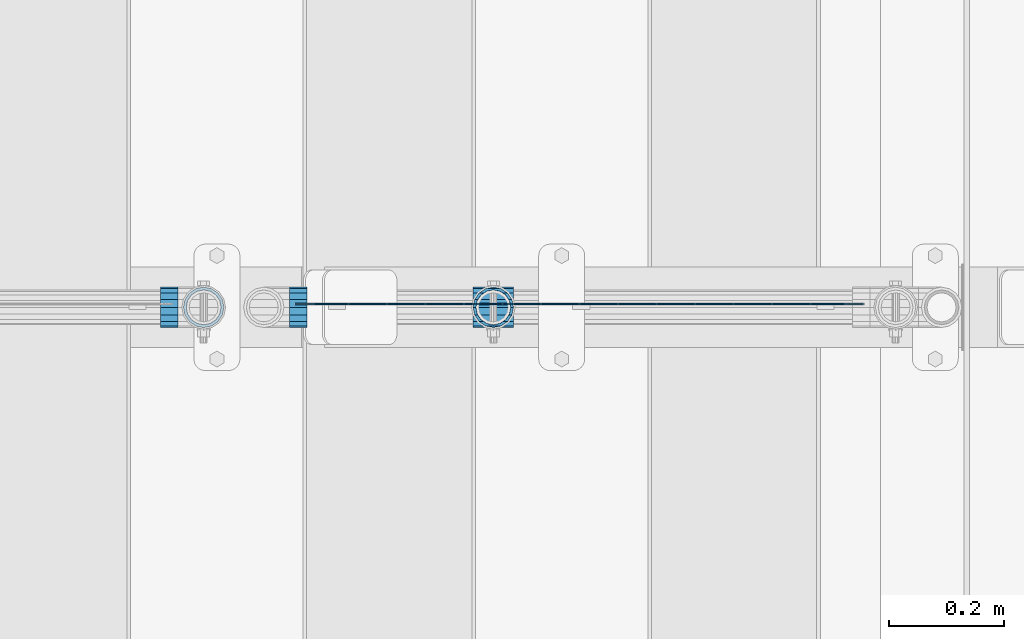
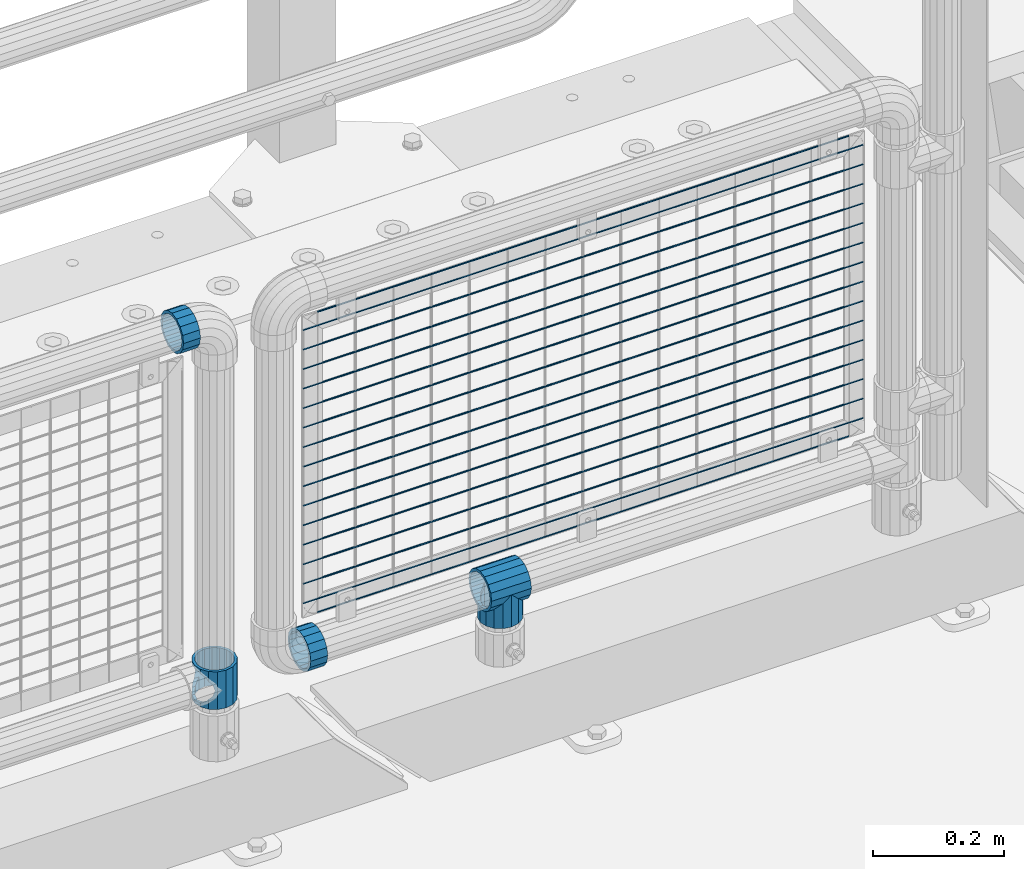
# One storey, part 124 of 193: 22 beams.
"""IFC2X3 building model written with IfcOpenShell, lengths in millimetres."""

from ifc_helpers import new_model, si_unit, frame, origin_with_axes, place, context, subcontext, project, spatial, faceted_brep, material, type_object, element, save


model = new_model("IFC2X3")

# Units and contexts
model_context = context("Model", 3, precision=1e-05, world=origin_with_axes())
body_context = subcontext(model_context, "Body", "Model", "MODEL_VIEW")
ifc_project = project(units=[si_unit("LENGTHUNIT", "METRE", prefix="MILLI"), si_unit("AREAUNIT", "SQUARE_METRE"), si_unit("VOLUMEUNIT", "CUBIC_METRE"), si_unit("MASSUNIT", "GRAM", prefix="KILO"), si_unit("TIMEUNIT", "SECOND"), si_unit("PLANEANGLEUNIT", "RADIAN"), si_unit("SOLIDANGLEUNIT", "STERADIAN"), si_unit("THERMODYNAMICTEMPERATUREUNIT", "DEGREE_CELSIUS"), si_unit("LUMINOUSINTENSITYUNIT", "LUMEN")], contexts=[model_context])

# Site, building, storey
site_placement = place(None, origin_with_axes())
site = spatial("IfcSite", under=ifc_project, at=site_placement, CompositionType="ELEMENT")
building_placement = place(site_placement, origin_with_axes())
building = spatial("IfcBuilding", under=site, at=building_placement, Name="Standard", CompositionType="ELEMENT")
storey_placement = place(building_placement, origin_with_axes())
storey = spatial("IfcBuildingStorey", under=building, at=storey_placement, Name="Undefined", CompositionType="ELEMENT", Elevation=0.0)

# Beams
ifc_material = material(Name="Misc_Undefined")
beam_type_1 = type_object("IfcBeamType", PredefinedType="NOTDEFINED")
beam_1_placement = place(storey_placement, frame((-30223.0, 28664.5, 333.820000000001), z_axis=(1.0, 0.0, 0.0), x_axis=(0.0, 0.0, -1.0)))
element("IfcBeam", 1, at=beam_1_placement, inside=storey, type_object=beam_type_1, material=ifc_material, context=body_context, shape_type="Brep", body=[
    faceted_brep([(46.7644421722801, 28.0397438117179, -11.614442172282), (46.7644421722801, 28.0397438117179, -20.0882031229849), (51.5310424080006, 24.8548033587067, -24.8548033587067), (56.6106908090114, 21.46069080901, -27.1226768591041), (56.6106908090114, 21.46069080901, -21.46069080901), (61.9623795176744, 13.4513226476338, -32.4743655677703), (63.1897438117172, 11.614442172282, -32.8397438117245), (63.1897438117172, 11.614442172282, -28.0397438117179), (65.4999999999997, 0.0, -35.1500000000015), (65.4999999999997, 0.0, -30.3499999999985), (63.1897438117172, -11.614442172282, -32.8397438117172), (63.1897438117172, -11.614442172282, -28.0397438117179), (61.9623795176767, -13.4513226476338, -32.4743655677703), (56.6106908090114, -21.46069080901, -27.1226768591114), (56.6106908090114, -21.46069080901, -21.46069080901), (51.5310424080006, -24.8548033587067, -24.8548033587067), (46.7644421722801, -28.0397438117179, -20.0882031229812), (46.7644421722801, -28.0397438117179, -11.614442172282), (35.1499999999996, -30.3499999999985, -16.6306603983721), (35.1500000000015, -30.35, 0.0), (23.5355578277191, -28.0397438117179, -20.0882031229812), (23.5355578277191, -28.0397438117179, -11.614442172282), (18.7689575919921, -24.8548033587067, -24.8548033587067), (13.6893091909879, -21.46069080901, -27.1226768591114), (13.6893091909879, -21.46069080901, -21.46069080901), (8.33762048232484, -13.4513226476338, -32.4743655677703), (7.11025618828211, -11.614442172282, -32.8397438117172), (7.11025618828211, -11.614442172282, -28.0397438117179), (4.79999999999961, 0.0, -35.1500000000015), (4.79999999999961, 0.0, -30.3499999999985), (7.11025618828211, 11.614442172282, -32.8397438117245), (7.11025618828211, 11.614442172282, -28.0397438117179), (8.33762048232262, 13.4513226476338, -32.4743655677703), (13.6893091909879, 21.46069080901, -27.1226768591041), (13.6893091909879, 21.46069080901, -21.46069080901), (18.7689575919987, 24.8548033587067, -24.8548033587067), (23.5355578277192, 28.0397438117179, -20.0882031229849), (23.5355578277192, 28.0397438117179, -11.614442172282), (35.1499999999996, 30.3499999999985, -16.6306603983685), (35.1500000000015, 30.35, 0.0), (0.0, 32.4743655677703, -13.4513226476338), (0.0, 35.1500000000015, 0.0), (70.2999999999993, 35.1500000000015, 0.0), (70.2999999999993, 32.4743655677703, -13.4513226476338), (0.0, 32.4743655677703, 13.4513226476338), (70.2999999999993, 32.4743655677703, 13.4513226476338), (0.0, 24.8548033587067, 24.8548033587067), (70.2999999999993, 24.8548033587067, 24.8548033587067), (0.0, 13.4513226476338, 32.4743655677703), (70.2999999999993, 13.4513226476338, 32.4743655677703), (0.0, 0.0, 35.1500000000015), (70.2999999999993, 0.0, 35.1500000000015), (0.0, -13.4513226476338, 32.4743655677703), (70.2999999999993, -13.4513226476338, 32.4743655677703), (0.0, -24.8548033587067, 24.8548033587067), (70.2999999999993, -24.8548033587067, 24.8548033587067), (0.0, -32.4743655677703, 13.4513226476338), (70.2999999999993, -32.4743655677703, 13.4513226476338), (0.0, -35.1500000000015, 0.0), (70.2999999999993, -35.1500000000015, 0.0), (70.2999999999993, -30.3499999999985, 0.0), (70.2999999999993, -28.0397438117179, -11.614442172282), (70.2999999999993, -21.46069080901, -21.46069080901), (70.2999999999993, -11.614442172282, -28.0397438117179), (70.2999999999993, 0.0, -30.3499999999985), (70.2999999999993, 11.614442172282, -28.0397438117179), (70.2999999999993, 21.46069080901, -21.46069080901), (70.2999999999993, 28.0397438117179, -11.614442172282), (0.0, -28.0397438117179, -11.614442172282), (0.0, -30.3499999999985, 0.0), (0.0, -21.46069080901, -21.46069080901), (0.0, -11.614442172282, -28.0397438117179), (0.0, 0.0, -30.3499999999985), (0.0, 11.614442172282, -28.0397438117179), (0.0, 21.46069080901, -21.46069080901), (0.0, 28.0397438117179, -11.614442172282), (0.0, 30.3499999999985, 0.0), (70.2999999999993, 30.3499999999985, 0.0), (0.0, 28.0397438117179, 11.614442172282), (70.2999999999993, 28.0397438117179, 11.614442172282), (0.0, 21.46069080901, 21.46069080901), (70.2999999999993, 21.46069080901, 21.46069080901), (0.0, 11.614442172282, 28.0397438117179), (70.2999999999993, 11.614442172282, 28.0397438117179), (0.0, 0.0, 30.3499999999985), (70.2999999999993, 0.0, 30.3499999999985), (0.0, -11.614442172282, 28.0397438117179), (70.2999999999993, -11.614442172282, 28.0397438117179), (0.0, -21.46069080901, 21.46069080901), (70.2999999999993, -21.46069080901, 21.46069080901), (0.0, -28.0397438117179, 11.614442172282), (70.2999999999993, -28.0397438117179, 11.614442172282), (70.2999999999993, -24.8548033587067, -24.8548033587067), (70.2999999999993, -13.4513226476338, -32.4743655677703), (70.2999999999993, 0.0, -35.1500000000015), (70.2999999999993, 13.4513226476338, -32.4743655677703), (70.2999999999993, 24.8548033587067, -24.8548033587067), (70.2999999999993, -32.4743655677703, -13.4513226476338), (0.0, -32.4743655677703, -13.4513226476338), (0.0, 24.8548033587067, -24.8548033587067), (0.0, 13.4513226476338, -32.4743655677703), (0.0, 0.0, -35.1500000000015), (0.0, -13.4513226476338, -32.4743655677703), (0.0, -24.8548033587067, -24.8548033587067)], [[[0, 1, 2, 3, 4]], [[4, 3, 5, 6, 7]], [[7, 6, 8, 9]], [[9, 8, 10, 11]], [[11, 10, 12, 13, 14]], [[14, 13, 15, 16, 17]], [[17, 16, 18, 19]], [[19, 18, 20, 21]], [[21, 20, 22, 23, 24]], [[24, 23, 25, 26, 27]], [[27, 26, 28, 29]], [[29, 28, 30, 31]], [[31, 30, 32, 33, 34]], [[34, 33, 35, 36, 37]], [[37, 36, 38, 39]], [[39, 38, 1, 0]], [[40, 41, 42, 43]], [[41, 44, 45, 42]], [[44, 46, 47, 45]], [[46, 48, 49, 47]], [[48, 50, 51, 49]], [[50, 52, 53, 51]], [[52, 54, 55, 53]], [[54, 56, 57, 55]], [[56, 58, 59, 57]], [[60, 61, 17, 19]], [[61, 62, 14, 17]], [[62, 63, 11, 14]], [[63, 64, 9, 11]], [[64, 65, 7, 9]], [[65, 66, 4, 7]], [[66, 67, 0, 4]], [[68, 69, 19, 21]], [[70, 68, 21, 24]], [[71, 70, 24, 27]], [[72, 71, 27, 29]], [[73, 72, 29, 31]], [[74, 73, 31, 34]], [[75, 74, 34, 37]], [[76, 75, 37, 39]], [[67, 77, 39, 0]], [[78, 76, 39, 77, 79]], [[80, 78, 79, 81]], [[82, 80, 81, 83]], [[84, 82, 83, 85]], [[86, 84, 85, 87]], [[88, 86, 87, 89]], [[90, 88, 89, 91]], [[19, 69, 90, 91, 60]], [[92, 93, 94, 95, 96, 43, 42, 45, 47, 49, 51, 53, 55, 57, 59, 97], [89, 87, 85, 83, 81, 79, 77, 67, 66, 65, 64, 63, 62, 61, 60, 91]], [[58, 98, 97, 59]], [[56, 54, 52, 50, 48, 46, 44, 41, 40, 99, 100, 101, 102, 103, 98, 58], [68, 70, 71, 72, 73, 74, 75, 76, 78, 80, 82, 84, 86, 88, 90, 69]], [[32, 100, 99, 35, 33]], [[28, 101, 100, 32, 30]], [[102, 101, 28, 26, 25]], [[103, 102, 25, 23, 22]], [[15, 92, 97, 98, 103, 22, 20, 18, 16]], [[12, 93, 92, 15, 13]], [[8, 94, 93, 12, 10]], [[95, 94, 8, 6, 5]], [[96, 95, 5, 3, 2]], [[35, 99, 40, 43, 96, 2, 1, 38, 36]]]),
])
beam_2_placement = place(storey_placement, frame((-29719.0, 28664.5, 298.169999999999), z_axis=(0.0, 1.0, 0.0), x_axis=(0.0, 0.0, -1.0)))
element("IfcBeam", 2, at=beam_2_placement, inside=storey, type_object=beam_type_1, material=ifc_material, context=body_context, shape_type="Brep", body=[
    faceted_brep([(0.0, 0.0, 35.1500000000015), (13.4513226476338, 13.4513226476329, 32.4743655677703), (13.4513226476338, -13.4513226476329, 32.4743655677703), (24.8548033587067, -16.3810424080013, -24.8548033587067), (24.8548033587067, -24.8548033587072, -24.8548033587067), (32.4743655677703, -32.4743655677717, -13.4513226476338), (32.4743655677703, -26.8123795176754, -13.4513226476338), (27.1226768591114, -21.4606908090117, -21.46069080901), (0.0, 0.0, -35.1500000000015), (13.4513226476338, -13.4513226476329, -32.4743655677703), (13.4513226476338, 13.4513226476329, -32.4743655677703), (20.0882031229849, -11.6144421722805, -28.0397438117179), (16.6306603983721, 0.0, -30.3499999999985), (20.0882031229849, 11.6144421722805, -28.0397438117179), (24.8548033587067, 16.3810424080013, -24.8548033587067), (24.8548033587067, 24.8548033587072, -24.8548033587067), (27.1226768591114, 21.4606908090117, -21.46069080901), (32.4743655677703, 26.8123795176776, -13.4513226476338), (32.4743655677703, 32.4743655677717, -13.4513226476338), (32.8397438117172, 28.0397438117175, -11.614442172282), (35.1500000000015, 30.35, 0.0), (35.1500000000015, 35.15, 0.0), (32.8397438117208, 28.0397438117175, 11.614442172282), (32.4743655677703, 26.8123795176754, 13.4513226476338), (32.4743655677703, 32.4743655677717, 13.4513226476338), (27.1226768591041, 21.4606908090117, 21.46069080901), (24.8548033587067, 16.3810424080078, 24.8548033587067), (24.8548033587067, 24.8548033587072, 24.8548033587067), (20.0882031229849, 11.6144421722805, 28.0397438117179), (16.6306603983685, 0.0, 30.3499999999985), (20.0882031229849, -11.6144421722805, 28.0397438117179), (24.8548033587067, -16.3810424080013, 24.8548033587067), (24.8548033587067, -24.8548033587072, 24.8548033587067), (27.1226768591041, -21.4606908090117, 21.46069080901), (32.4743655677703, -26.8123795176776, 13.4513226476338), (32.4743655677703, -32.4743655677717, 13.4513226476338), (32.8397438117208, -28.0397438117175, 11.614442172282), (35.1500000000015, -30.35, 0.0), (35.1500000000015, -35.15, 0.0), (32.8397438117172, -28.0397438117175, -11.614442172282), (60.1500000000015, -24.8548033587072, -24.8548033587067), (60.1500000000015, -32.4743655677717, -13.4513226476338), (60.1500000000015, -13.4513226476329, -32.4743655677703), (60.1500000000015, 0.0, -35.1500000000015), (60.1500000000015, 13.4513226476329, -32.4743655677703), (60.1500000000015, 24.8548033587072, -24.8548033587067), (60.1500000000015, 32.4743655677717, -13.4513226476338), (60.1500000000015, 35.15, 0.0), (60.1500000000015, 32.4743655677717, 13.4513226476338), (60.1500000000015, 24.8548033587072, 24.8548033587067), (60.1500000000015, 13.4513226476329, 32.4743655677703), (60.1500000000015, 0.0, 35.1500000000015), (60.1500000000015, -13.4513226476329, 32.4743655677703), (60.1500000000015, -24.8548033587072, 24.8548033587067), (60.1500000000015, -32.4743655677717, 13.4513226476338), (60.1500000000015, -35.15, 0.0), (60.1500000000015, -21.4606908090117, 21.46069080901), (60.1500000000015, -11.6144421722805, 28.0397438117179), (60.1500000000015, 0.0, 30.3499999999985), (60.1500000000015, 11.6144421722805, 28.0397438117179), (60.1500000000015, 21.4606908090117, 21.46069080901), (60.1500000000015, 28.0397438117175, 11.614442172282), (60.1500000000015, 30.35, 0.0), (60.1500000000015, 28.0397438117175, -11.614442172282), (60.1500000000015, 21.4606908090117, -21.46069080901), (60.1500000000015, 11.6144421722805, -28.0397438117179), (60.1500000000015, 0.0, -30.3499999999985), (60.1500000000015, -11.6144421722805, -28.0397438117179), (60.1500000000015, -21.4606908090117, -21.46069080901), (60.1500000000015, -28.0397438117175, -11.614442172282), (60.1500000000015, -30.35, 0.0), (60.1500000000015, -28.0397438117175, 11.614442172282)], [[[0, 1, 2]], [[3, 4, 5, 6, 7]], [[8, 9, 10]], [[10, 9, 4, 3, 11, 12, 13, 14, 15]], [[15, 14, 16, 17, 18]], [[18, 17, 19, 20, 21]], [[21, 20, 22, 23, 24]], [[24, 23, 25, 26, 27]], [[27, 26, 28, 29, 30, 31, 32, 2, 1]], [[33, 34, 35, 32, 31]], [[36, 37, 38, 35, 34]], [[6, 5, 38, 37, 39]], [[40, 41, 5, 4]], [[42, 40, 4, 9]], [[43, 42, 9, 8]], [[44, 43, 8, 10]], [[45, 44, 10, 15]], [[46, 45, 15, 18]], [[47, 46, 18, 21]], [[48, 47, 21, 24]], [[49, 48, 24, 27]], [[50, 49, 27, 1]], [[51, 50, 1, 0]], [[52, 51, 0, 2]], [[53, 52, 2, 32]], [[54, 53, 32, 35]], [[55, 54, 35, 38]], [[41, 55, 38, 5]], [[40, 42, 43, 44, 45, 46, 47, 48, 49, 50, 51, 52, 53, 54, 55, 41], [56, 57, 58, 59, 60, 61, 62, 63, 64, 65, 66, 67, 68, 69, 70, 71]], [[71, 70, 37, 36]], [[56, 71, 36, 34, 33]], [[57, 56, 33, 31, 30]], [[58, 57, 30, 29]], [[59, 58, 29, 28]], [[25, 60, 59, 28, 26]], [[22, 61, 60, 25, 23]], [[62, 61, 22, 20]], [[63, 62, 20, 19]], [[64, 63, 19, 17, 16]], [[65, 64, 16, 14, 13]], [[66, 65, 13, 12]], [[67, 66, 12, 11]], [[7, 68, 67, 11, 3]], [[39, 69, 68, 7, 6]], [[70, 69, 39, 37]]]),
])
beam_3_placement = place(storey_placement, frame((-29754.15, 28664.5, 298.169999999999), z_axis=(0.0, 0.0, 1.0), x_axis=(1.0, 0.0, 0.0)))
element("IfcBeam", 3, at=beam_3_placement, inside=storey, type_object=beam_type_1, material=ifc_material, context=body_context, shape_type="Brep", body=[
    faceted_brep([(63.1897438117172, -11.614442172282, -28.0397438117179), (63.1897438117172, -11.614442172282, -32.8397438117172), (61.9623795176767, -13.4513226476338, -32.4743655677703), (56.6106908090114, -21.46069080901, -27.1226768591114), (56.6106908090114, -21.46069080901, -21.46069080901), (51.5310424080006, -24.8548033587067, -24.8548033587067), (46.7644421722801, -28.0397438117179, -20.0882031229812), (46.7644421722801, -28.0397438117179, -11.614442172282), (35.1499999999996, -30.3499999999985, -16.6306603983721), (35.1500000000015, -30.35, 0.0), (23.5355578277191, -28.0397438117179, -20.0882031229812), (23.5355578277191, -28.0397438117179, -11.614442172282), (18.7689575919921, -24.8548033587067, -24.8548033587067), (13.6893091909879, -21.46069080901, -27.1226768591114), (13.6893091909879, -21.46069080901, -21.46069080901), (8.33762048232484, -13.4513226476338, -32.4743655677703), (7.11025618828211, -11.614442172282, -32.8397438117172), (7.11025618828211, -11.614442172282, -28.0397438117179), (4.79999999999961, 0.0, -35.1500000000015), (4.79999999999961, 0.0, -30.3499999999985), (7.11025618828211, 11.614442172282, -32.8397438117245), (7.11025618828211, 11.614442172282, -28.0397438117179), (8.33762048232262, 13.4513226476338, -32.4743655677703), (13.6893091909879, 21.46069080901, -27.1226768591041), (13.6893091909879, 21.46069080901, -21.46069080901), (18.7689575919987, 24.8548033587067, -24.8548033587067), (23.5355578277192, 28.0397438117179, -20.0882031229849), (23.5355578277192, 28.0397438117179, -11.614442172282), (35.1499999999996, 30.3499999999985, -16.6306603983685), (35.1500000000015, 30.35, 0.0), (46.7644421722801, 28.0397438117179, -20.0882031229849), (46.7644421722801, 28.0397438117179, -11.614442172282), (51.5310424080006, 24.8548033587067, -24.8548033587067), (56.6106908090114, 21.46069080901, -27.1226768591041), (56.6106908090114, 21.46069080901, -21.46069080901), (61.9623795176744, 13.4513226476338, -32.4743655677703), (63.1897438117172, 11.614442172282, -32.8397438117245), (63.1897438117172, 11.614442172282, -28.0397438117179), (65.4999999999997, 0.0, -35.1500000000015), (65.4999999999997, 0.0, -30.3499999999985), (0.0, -21.46069080901, -21.46069080901), (0.0, -28.0397438117179, -11.614442172282), (0.0, -11.614442172282, -28.0397438117179), (0.0, 0.0, -30.3499999999985), (0.0, 11.614442172282, -28.0397438117179), (0.0, 21.46069080901, -21.46069080901), (0.0, 28.0397438117179, -11.614442172282), (0.0, 30.3499999999985, 0.0), (0.0, 32.4743655677703, -13.4513226476338), (0.0, 35.1500000000015, 0.0), (70.2999999999993, 35.1500000000015, 0.0), (70.2999999999993, 32.4743655677703, -13.4513226476338), (0.0, 32.4743655677703, 13.4513226476338), (70.2999999999993, 32.4743655677703, 13.4513226476338), (0.0, 24.8548033587067, 24.8548033587067), (70.2999999999993, 24.8548033587067, 24.8548033587067), (0.0, 13.4513226476338, 32.4743655677703), (70.2999999999993, 13.4513226476338, 32.4743655677703), (0.0, 0.0, 35.1500000000015), (70.2999999999993, 0.0, 35.1500000000015), (0.0, -13.4513226476338, 32.4743655677703), (70.2999999999993, -13.4513226476338, 32.4743655677703), (0.0, -24.8548033587067, 24.8548033587067), (70.2999999999993, -24.8548033587067, 24.8548033587067), (0.0, -32.4743655677703, 13.4513226476338), (70.2999999999993, -32.4743655677703, 13.4513226476338), (0.0, -35.1500000000015, 0.0), (70.2999999999993, -35.1500000000015, 0.0), (0.0, -32.4743655677703, -13.4513226476338), (70.2999999999993, -32.4743655677703, -13.4513226476338), (0.0, 24.8548033587067, -24.8548033587067), (0.0, 13.4513226476338, -32.4743655677703), (0.0, 0.0, -35.1500000000015), (0.0, -13.4513226476338, -32.4743655677703), (0.0, -24.8548033587067, -24.8548033587067), (0.0, 28.0397438117179, 11.614442172282), (0.0, 21.46069080901, 21.46069080901), (0.0, 11.614442172282, 28.0397438117179), (0.0, 0.0, 30.3499999999985), (0.0, -11.614442172282, 28.0397438117179), (0.0, -21.46069080901, 21.46069080901), (0.0, -28.0397438117179, 11.614442172282), (0.0, -30.3499999999985, 0.0), (70.2999999999993, -30.3499999999985, 0.0), (70.2999999999993, -28.0397438117179, -11.614442172282), (70.2999999999993, -21.46069080901, -21.46069080901), (70.2999999999993, -11.614442172282, -28.0397438117179), (70.2999999999993, 0.0, -30.3499999999985), (70.2999999999993, 21.46069080901, -21.46069080901), (70.2999999999993, 28.0397438117179, -11.614442172282), (70.2999999999993, 11.614442172282, -28.0397438117179), (70.2999999999993, 30.3499999999985, 0.0), (70.2999999999993, 28.0397438117179, 11.614442172282), (70.2999999999993, 21.46069080901, 21.46069080901), (70.2999999999993, 11.614442172282, 28.0397438117179), (70.2999999999993, 0.0, 30.3499999999985), (70.2999999999993, -11.614442172282, 28.0397438117179), (70.2999999999993, -21.46069080901, 21.46069080901), (70.2999999999993, -28.0397438117179, 11.614442172282), (70.2999999999993, -24.8548033587067, -24.8548033587067), (70.2999999999993, -13.4513226476338, -32.4743655677703), (70.2999999999993, 0.0, -35.1500000000015), (70.2999999999993, 13.4513226476338, -32.4743655677703), (70.2999999999993, 24.8548033587067, -24.8548033587067)], [[[0, 1, 2, 3, 4]], [[4, 3, 5, 6, 7]], [[7, 6, 8, 9]], [[9, 8, 10, 11]], [[11, 10, 12, 13, 14]], [[14, 13, 15, 16, 17]], [[17, 16, 18, 19]], [[19, 18, 20, 21]], [[21, 20, 22, 23, 24]], [[24, 23, 25, 26, 27]], [[27, 26, 28, 29]], [[29, 28, 30, 31]], [[31, 30, 32, 33, 34]], [[34, 33, 35, 36, 37]], [[37, 36, 38, 39]], [[39, 38, 1, 0]], [[40, 41, 11, 14]], [[42, 40, 14, 17]], [[43, 42, 17, 19]], [[44, 43, 19, 21]], [[45, 44, 21, 24]], [[46, 45, 24, 27]], [[47, 46, 27, 29]], [[48, 49, 50, 51]], [[49, 52, 53, 50]], [[52, 54, 55, 53]], [[54, 56, 57, 55]], [[56, 58, 59, 57]], [[58, 60, 61, 59]], [[60, 62, 63, 61]], [[62, 64, 65, 63]], [[64, 66, 67, 65]], [[66, 68, 69, 67]], [[64, 62, 60, 58, 56, 54, 52, 49, 48, 70, 71, 72, 73, 74, 68, 66], [41, 40, 42, 43, 44, 45, 46, 47, 75, 76, 77, 78, 79, 80, 81, 82]], [[41, 82, 9, 11]], [[83, 84, 7, 9]], [[84, 85, 4, 7]], [[85, 86, 0, 4]], [[86, 87, 39, 0]], [[88, 89, 31, 34]], [[90, 88, 34, 37]], [[87, 90, 37, 39]], [[89, 91, 29, 31]], [[75, 47, 29, 91, 92]], [[76, 75, 92, 93]], [[77, 76, 93, 94]], [[78, 77, 94, 95]], [[79, 78, 95, 96]], [[80, 79, 96, 97]], [[81, 80, 97, 98]], [[9, 82, 81, 98, 83]], [[99, 100, 101, 102, 103, 51, 50, 53, 55, 57, 59, 61, 63, 65, 67, 69], [97, 96, 95, 94, 93, 92, 91, 89, 88, 90, 87, 86, 85, 84, 83, 98]], [[102, 101, 38, 36, 35]], [[103, 102, 35, 33, 32]], [[25, 70, 48, 51, 103, 32, 30, 28, 26]], [[22, 71, 70, 25, 23]], [[18, 72, 71, 22, 20]], [[73, 72, 18, 16, 15]], [[74, 73, 15, 13, 12]], [[5, 99, 69, 68, 74, 12, 10, 8, 6]], [[2, 100, 99, 5, 3]], [[38, 101, 100, 2, 1]]]),
])
beam_4_placement = place(storey_placement, frame((-30268.0, 28664.5, 969.85), z_axis=(0.0, 0.0, 1.0), x_axis=(-1.0, 0.0, 0.0)))
element("IfcBeam", 4, at=beam_4_placement, inside=storey, type_object=beam_type_1, material=ifc_material, context=body_context, shape_type="Brep", body=[
    faceted_brep([(0.0, -30.3499999999985, 0.0), (0.0, -28.0397438117179, 11.614442172282), (30.0, -28.0397438117179, 11.6144421722805), (30.0, -30.3499999999985, 0.0), (0.0, -21.46069080901, 21.46069080901), (30.0, -21.46069080901, 21.4606908090117), (0.0, -11.614442172282, 28.0397438117179), (30.0, -11.614442172282, 28.0397438117176), (0.0, 0.0, 30.3499999999985), (30.0, 0.0, 30.35), (0.0, 11.614442172282, 28.0397438117179), (30.0, 11.614442172282, 28.0397438117176), (0.0, 21.46069080901, 21.46069080901), (30.0, 21.46069080901, 21.4606908090117), (0.0, 28.0397438117179, 11.614442172282), (30.0, 28.0397438117179, 11.6144421722805), (0.0, 30.3499999999985, 0.0), (30.0, 30.3499999999985, 0.0), (0.0, 28.0397438117179, -11.614442172282), (30.0, 28.0397438117179, -11.6144421722805), (0.0, 21.46069080901, -21.46069080901), (30.0, 21.46069080901, -21.4606908090117), (0.0, 11.614442172282, -28.0397438117179), (30.0, 11.614442172282, -28.0397438117176), (0.0, 0.0, -30.3499999999985), (30.0, 0.0, -30.35), (0.0, -11.614442172282, -28.0397438117179), (30.0, -11.614442172282, -28.0397438117176), (0.0, -21.46069080901, -21.46069080901), (30.0, -21.46069080901, -21.4606908090117), (0.0, -28.0397438117179, -11.614442172282), (30.0, -28.0397438117179, -11.6144421722805), (0.0, -35.1500000000015, 0.0), (0.0, -32.4743655677703, -13.4513226476338), (30.0, -32.4743655677703, -13.4513226476329), (30.0, -35.1500000000015, 0.0), (0.0, -24.8548033587067, -24.8548033587067), (30.0, -24.8548033587067, -24.8548033587072), (0.0, -13.4513226476338, -32.4743655677703), (30.0, -13.4513226476338, -32.4743655677718), (0.0, 0.0, -35.1500000000015), (30.0, 0.0, -35.15), (0.0, 13.4513226476338, -32.4743655677703), (30.0, 13.4513226476338, -32.4743655677718), (0.0, 24.8548033587067, -24.8548033587067), (30.0, 24.8548033587067, -24.8548033587072), (0.0, 32.4743655677703, -13.4513226476338), (30.0, 32.4743655677703, -13.4513226476329), (0.0, 35.1500000000015, 0.0), (30.0, 35.1500000000015, 0.0), (0.0, 32.4743655677703, 13.4513226476338), (30.0, 32.4743655677703, 13.4513226476329), (0.0, 24.8548033587067, 24.8548033587067), (30.0, 24.8548033587067, 24.8548033587072), (0.0, 13.4513226476338, 32.4743655677703), (30.0, 13.4513226476338, 32.4743655677718), (0.0, 0.0, 35.1500000000015), (30.0, 0.0, 35.15), (0.0, -13.4513226476338, 32.4743655677703), (30.0, -13.4513226476338, 32.4743655677718), (0.0, -24.8548033587067, 24.8548033587067), (30.0, -24.8548033587067, 24.8548033587072), (0.0, -32.4743655677703, 13.4513226476338), (30.0, -32.4743655677703, 13.4513226476329)], [[[0, 1, 2, 3]], [[1, 4, 5, 2]], [[4, 6, 7, 5]], [[6, 8, 9, 7]], [[8, 10, 11, 9]], [[10, 12, 13, 11]], [[12, 14, 15, 13]], [[14, 16, 17, 15]], [[16, 18, 19, 17]], [[18, 20, 21, 19]], [[20, 22, 23, 21]], [[22, 24, 25, 23]], [[24, 26, 27, 25]], [[26, 28, 29, 27]], [[28, 30, 31, 29]], [[30, 0, 3, 31]], [[32, 33, 34, 35]], [[33, 36, 37, 34]], [[36, 38, 39, 37]], [[38, 40, 41, 39]], [[40, 42, 43, 41]], [[42, 44, 45, 43]], [[44, 46, 47, 45]], [[46, 48, 49, 47]], [[48, 50, 51, 49]], [[50, 52, 53, 51]], [[52, 54, 55, 53]], [[54, 56, 57, 55]], [[56, 58, 59, 57]], [[58, 60, 61, 59]], [[60, 62, 63, 61]], [[62, 32, 35, 63]], [[37, 39, 41, 43, 45, 47, 49, 51, 53, 55, 57, 59, 61, 63, 35, 34], [5, 7, 9, 11, 13, 15, 17, 19, 21, 23, 25, 27, 29, 31, 3, 2]], [[62, 60, 58, 56, 54, 52, 50, 48, 46, 44, 42, 40, 38, 36, 33, 32], [30, 28, 26, 24, 22, 20, 18, 16, 14, 12, 10, 8, 6, 4, 1, 0]]]),
])
beam_5_placement = place(storey_placement, frame((-30073.39, 28664.5, 298.170000000001), z_axis=(0.0, 0.0, -1.0), x_axis=(1.0, 0.0, 0.0)))
element("IfcBeam", 5, at=beam_5_placement, inside=storey, type_object=beam_type_1, material=ifc_material, context=body_context, shape_type="Brep", body=[
    faceted_brep([(0.0, -30.3499999999985, 0.0), (0.0, -28.0397438117179, 11.614442172282), (30.0, -28.0397438117179, 11.6144421722805), (30.0, -30.3499999999985, 0.0), (0.0, -21.46069080901, 21.46069080901), (30.0, -21.46069080901, 21.4606908090117), (0.0, -11.614442172282, 28.0397438117179), (30.0, -11.614442172282, 28.0397438117176), (0.0, 0.0, 30.3499999999985), (30.0, 0.0, 30.35), (0.0, 11.614442172282, 28.0397438117179), (30.0, 11.614442172282, 28.0397438117176), (0.0, 21.46069080901, 21.46069080901), (30.0, 21.46069080901, 21.4606908090117), (0.0, 28.0397438117179, 11.614442172282), (30.0, 28.0397438117179, 11.6144421722805), (0.0, 30.3499999999985, 0.0), (30.0, 30.3499999999985, 0.0), (0.0, 28.0397438117179, -11.614442172282), (30.0, 28.0397438117179, -11.6144421722805), (0.0, 21.46069080901, -21.46069080901), (30.0, 21.46069080901, -21.4606908090117), (0.0, 11.614442172282, -28.0397438117179), (30.0, 11.614442172282, -28.0397438117176), (0.0, 0.0, -30.3499999999985), (30.0, 0.0, -30.35), (0.0, -11.614442172282, -28.0397438117179), (30.0, -11.614442172282, -28.0397438117176), (0.0, -21.46069080901, -21.46069080901), (30.0, -21.46069080901, -21.4606908090117), (0.0, -28.0397438117179, -11.614442172282), (30.0, -28.0397438117179, -11.6144421722805), (0.0, -35.1500000000015, 0.0), (0.0, -32.4743655677703, -13.4513226476338), (30.0, -32.4743655677703, -13.4513226476329), (30.0, -35.1500000000015, 0.0), (0.0, -24.8548033587067, -24.8548033587067), (30.0, -24.8548033587067, -24.8548033587072), (0.0, -13.4513226476338, -32.4743655677703), (30.0, -13.4513226476338, -32.4743655677718), (0.0, 0.0, -35.1500000000015), (30.0, 0.0, -35.15), (0.0, 13.4513226476338, -32.4743655677703), (30.0, 13.4513226476338, -32.4743655677718), (0.0, 24.8548033587067, -24.8548033587067), (30.0, 24.8548033587067, -24.8548033587072), (0.0, 32.4743655677703, -13.4513226476338), (30.0, 32.4743655677703, -13.4513226476329), (0.0, 35.1500000000015, 0.0), (30.0, 35.1500000000015, 0.0), (0.0, 32.4743655677703, 13.4513226476338), (30.0, 32.4743655677703, 13.4513226476329), (0.0, 24.8548033587067, 24.8548033587067), (30.0, 24.8548033587067, 24.8548033587072), (0.0, 13.4513226476338, 32.4743655677703), (30.0, 13.4513226476338, 32.4743655677718), (0.0, 0.0, 35.1500000000015), (30.0, 0.0, 35.15), (0.0, -13.4513226476338, 32.4743655677703), (30.0, -13.4513226476338, 32.4743655677718), (0.0, -24.8548033587067, 24.8548033587067), (30.0, -24.8548033587067, 24.8548033587072), (0.0, -32.4743655677703, 13.4513226476338), (30.0, -32.4743655677703, 13.4513226476329)], [[[0, 1, 2, 3]], [[1, 4, 5, 2]], [[4, 6, 7, 5]], [[6, 8, 9, 7]], [[8, 10, 11, 9]], [[10, 12, 13, 11]], [[12, 14, 15, 13]], [[14, 16, 17, 15]], [[16, 18, 19, 17]], [[18, 20, 21, 19]], [[20, 22, 23, 21]], [[22, 24, 25, 23]], [[24, 26, 27, 25]], [[26, 28, 29, 27]], [[28, 30, 31, 29]], [[30, 0, 3, 31]], [[32, 33, 34, 35]], [[33, 36, 37, 34]], [[36, 38, 39, 37]], [[38, 40, 41, 39]], [[40, 42, 43, 41]], [[42, 44, 45, 43]], [[44, 46, 47, 45]], [[46, 48, 49, 47]], [[48, 50, 51, 49]], [[50, 52, 53, 51]], [[52, 54, 55, 53]], [[54, 56, 57, 55]], [[56, 58, 59, 57]], [[58, 60, 61, 59]], [[60, 62, 63, 61]], [[62, 32, 35, 63]], [[37, 39, 41, 43, 45, 47, 49, 51, 53, 55, 57, 59, 61, 63, 35, 34], [5, 7, 9, 11, 13, 15, 17, 19, 21, 23, 25, 27, 29, 31, 3, 2]], [[62, 60, 58, 56, 54, 52, 50, 48, 46, 44, 42, 40, 38, 36, 33, 32], [30, 28, 26, 24, 22, 20, 18, 16, 14, 12, 10, 8, 6, 4, 1, 0]]]),
])
beam_type_2 = type_object("IfcBeamType", Name="D3", PredefinedType="NOTDEFINED")
for number, where, z_axis, x_axis in (
    (6, (-30063.39, 28670.4999883346, 633.023), (0.0, 0.0, 1.0), (1.0, 0.0, 0.0)),
    (7, (-30063.39, 28670.4999883385, 815.168), (0.0, 0.0, 1.0), (1.0, 0.0, 0.0)),
    (8, (-30063.39, 28670.4999883354, 669.452), (0.0, 0.0, 1.0), (1.0, 0.0, 0.0)),
    (9, (-30063.39, 28670.4999883338, 596.594000000001), (0.0, 0.0, 1.0), (1.0, 0.0, 0.0)),
    (10, (-30063.39, 28670.4999883331, 560.165), (0.0, 0.0, 1.0), (1.0, 0.0, 0.0)),
    (11, (-30063.39, 28670.4999883377, 778.739), (0.0, 0.0, 1.0), (1.0, 0.0, 0.0)),
    (12, (-30063.39, 28670.4999883323, 523.736), (0.0, 0.0, 1.0), (1.0, 0.0, 0.0)),
    (13, (-30063.39, 28670.4999883392, 851.597), (0.0, 0.0, 1.0), (1.0, 0.0, 0.0)),
    (14, (-30063.39, 28670.4999883315, 487.307), (0.0, 0.0, 1.0), (1.0, 0.0, 0.0)),
    (15, (-30063.39, 28670.4999883361, 705.881), (0.0, 0.0, 1.0), (1.0, 0.0, 0.0)),
    (16, (-30063.39, 28670.4999883308, 450.878), (0.0, 0.0, 1.0), (1.0, 0.0, 0.0)),
    (17, (-30063.39, 28670.49998834, 888.026), (0.0, 0.0, 1.0), (1.0, 0.0, 0.0)),
    (18, (-30063.39, 28670.4999883369, 742.31), (0.0, 0.0, 1.0), (1.0, 0.0, 0.0)),
    (19, (-30063.39, 28670.49998833, 414.449), (0.0, 0.0, 1.0), (1.0, 0.0, 0.0)),
):
    element("IfcBeam", number, at=place(storey_placement, frame(where, z_axis=z_axis, x_axis=x_axis)), inside=storey, type_object=beam_type_2, material=ifc_material, ObjectType="D3", context=body_context, shape_type="Brep", body=[
        faceted_brep([(0.0, -1.49999999999636, 3.63797880709171e-12), (0.0, -0.75, -1.29903810567669), (988.390000000287, -0.750000000003638, -1.29903810567669), (988.390000000287, -1.50000000000364, 0.0), (0.0, 0.75, -1.29903810567669), (988.390000000287, 0.749999999996362, -1.29903810567669), (0.0, 1.50000000000364, 7.27595761418343e-12), (988.390000000287, 1.49999999999636, 0.0), (0.0, 0.75, 1.29903810567669), (988.390000000287, 0.749999999996362, 1.29903810567669), (0.0, -0.75, 1.29903810567669), (988.390000000287, -0.750000000003638, 1.29903810567669)], [[[0, 1, 2, 3]], [[1, 4, 5, 2]], [[4, 6, 7, 5]], [[6, 8, 9, 7]], [[8, 10, 11, 9]], [[10, 0, 3, 11]], [[5, 7, 9, 11, 3, 2]], [[10, 8, 6, 4, 1, 0]]]),
    ])
beam_6_placement = place(storey_placement, frame((-30038.39, 28670.4999830243, 353.02), z_axis=(0.0, 0.0, 1.0), x_axis=(1.0, 0.0, 0.0)))
element("IfcBeam", 20, at=beam_6_placement, inside=storey, type_object=beam_type_2, material=ifc_material, ObjectType="D3", context=body_context, shape_type="Brep", body=[
    faceted_brep([(0.0, -1.49999999999636, 3.63797880709171e-12), (0.0, -0.75, -1.29903810567669), (938.390000000127, -0.75, -1.29903810567669), (938.390000000127, -1.5, 0.0), (0.0, 0.75, -1.29903810567669), (938.390000000127, 0.750000000003638, -1.29903810567663), (0.0, 1.50000000000364, 7.27595761418343e-12), (938.390000000127, 1.50000000000364, 0.0), (0.0, 0.75, 1.29903810567669), (938.390000000127, 0.750000000003638, 1.29903810567669), (0.0, -0.75, 1.29903810567669), (938.390000000127, -0.75, 1.29903810567669)], [[[0, 1, 2, 3]], [[1, 4, 5, 2]], [[4, 6, 7, 5]], [[6, 8, 9, 7]], [[8, 10, 11, 9]], [[10, 0, 3, 11]], [[5, 7, 9, 11, 3, 2]], [[10, 8, 6, 4, 1, 0]]]),
])
beam_7_placement = place(storey_placement, frame((-30063.39, 28670.4999883292, 378.02), z_axis=(0.0, 0.0, 1.0), x_axis=(1.0, 0.0, 0.0)))
element("IfcBeam", 21, at=beam_7_placement, inside=storey, type_object=beam_type_2, material=ifc_material, ObjectType="D3", context=body_context, shape_type="Brep", body=[
    faceted_brep([(0.0, -1.49999999999636, 3.63797880709171e-12), (0.0, -0.75, -1.29903810567669), (988.390000000287, -0.750000000003638, -1.29903810567669), (988.390000000287, -1.50000000000364, 0.0), (0.0, 0.75, -1.29903810567669), (988.390000000287, 0.749999999996362, -1.29903810567669), (0.0, 1.50000000000364, 7.27595761418343e-12), (988.390000000287, 1.49999999999636, 0.0), (0.0, 0.75, 1.29903810567669), (988.390000000287, 0.749999999996362, 1.29903810567669), (0.0, -0.75, 1.29903810567669), (988.390000000287, -0.750000000003638, 1.29903810567669)], [[[0, 1, 2, 3]], [[1, 4, 5, 2]], [[4, 6, 7, 5]], [[6, 8, 9, 7]], [[8, 10, 11, 9]], [[10, 0, 3, 11]], [[5, 7, 9, 11, 3, 2]], [[10, 8, 6, 4, 1, 0]]]),
])
beam_8_placement = place(storey_placement, frame((-30038.39, 28670.49998304, 913.02), z_axis=(0.0, 0.0, 1.0), x_axis=(1.0, 0.0, 0.0)))
element("IfcBeam", 22, at=beam_8_placement, inside=storey, type_object=beam_type_2, material=ifc_material, ObjectType="D3", context=body_context, shape_type="Brep", body=[
    faceted_brep([(0.0, -1.49999999999636, 3.63797880709171e-12), (0.0, -0.75, -1.29903810567669), (938.390000000127, -0.75, -1.29903810567669), (938.390000000127, -1.5, 0.0), (0.0, 0.75, -1.29903810567669), (938.390000000127, 0.750000000003638, -1.29903810567663), (0.0, 1.50000000000364, 7.27595761418343e-12), (938.390000000127, 1.50000000000364, 0.0), (0.0, 0.75, 1.29903810567669), (938.390000000127, 0.750000000003638, 1.29903810567669), (0.0, -0.75, 1.29903810567669), (938.390000000127, -0.75, 1.29903810567669)], [[[0, 1, 2, 3]], [[1, 4, 5, 2]], [[4, 6, 7, 5]], [[6, 8, 9, 7]], [[8, 10, 11, 9]], [[10, 0, 3, 11]], [[5, 7, 9, 11, 3, 2]], [[10, 8, 6, 4, 1, 0]]]),
])

save(model, "model.ifc")
